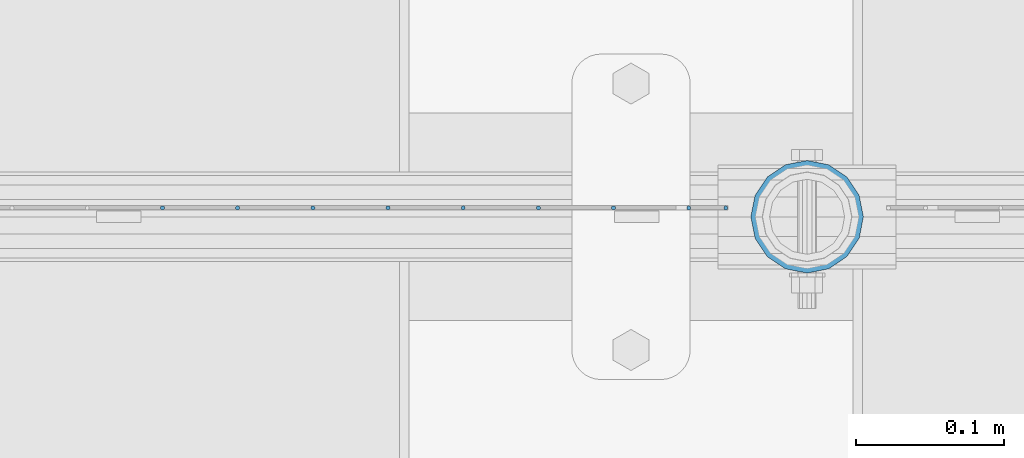
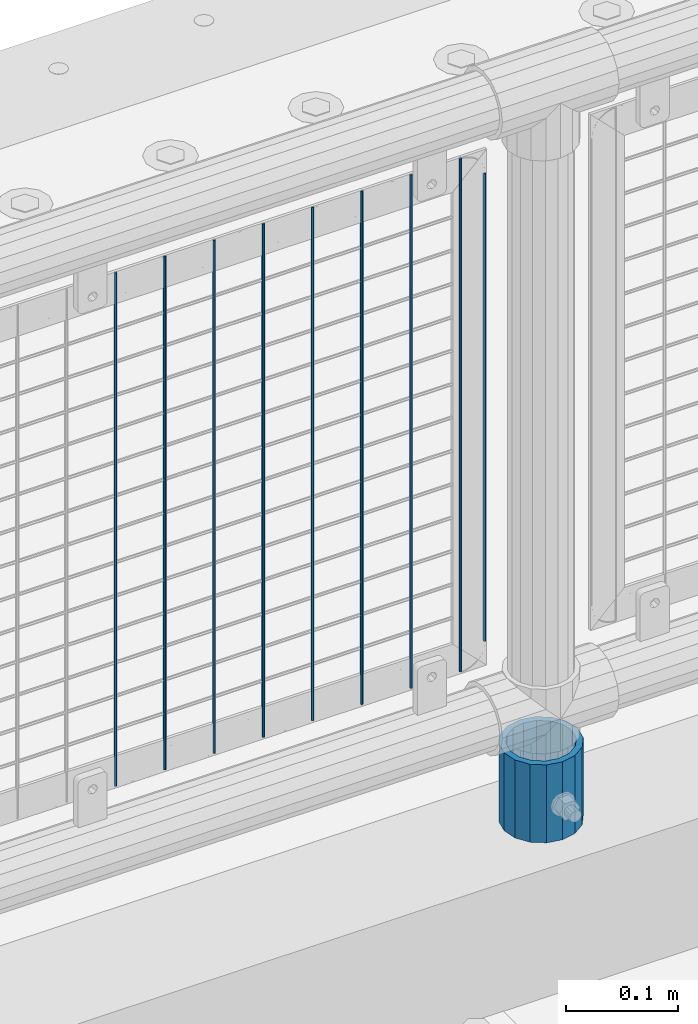
# One storey, part 85 of 242: 10 columns.
"""IFC2X3 building model written with IfcOpenShell, lengths in millimetres."""

from ifc_helpers import new_model, si_unit, frame, origin_with_axes, place, context, subcontext, project, spatial, faceted_brep, material, type_object, element, save


model = new_model("IFC2X3")

# Units and contexts
model_context = context("Model", 3, precision=1e-05, world=origin_with_axes())
body_context = subcontext(model_context, "Body", "Model", "MODEL_VIEW")
ifc_project = project(units=[si_unit("LENGTHUNIT", "METRE", prefix="MILLI"), si_unit("AREAUNIT", "SQUARE_METRE"), si_unit("VOLUMEUNIT", "CUBIC_METRE"), si_unit("MASSUNIT", "GRAM", prefix="KILO"), si_unit("TIMEUNIT", "SECOND"), si_unit("PLANEANGLEUNIT", "RADIAN"), si_unit("SOLIDANGLEUNIT", "STERADIAN"), si_unit("THERMODYNAMICTEMPERATUREUNIT", "DEGREE_CELSIUS"), si_unit("LUMINOUSINTENSITYUNIT", "LUMEN")], contexts=[model_context])

# Site, building, storey
site_placement = place(None, origin_with_axes())
site = spatial("IfcSite", under=ifc_project, at=site_placement, CompositionType="ELEMENT")
building_placement = place(site_placement, origin_with_axes())
building = spatial("IfcBuilding", under=site, at=building_placement, Name="Standard", CompositionType="ELEMENT")
storey_placement = place(building_placement, origin_with_axes())
storey = spatial("IfcBuildingStorey", under=building, at=storey_placement, Name="Undefined", CompositionType="ELEMENT", Elevation=0.0)

# Columns
ifc_material_1 = material(Name="Misc_Undefined")
column_type_1 = type_object("IfcColumnType", Name="D3", PredefinedType="NOTDEFINED")
for number, where, z_axis, x_axis in (
    (1, (-32161.796, -19329.5, 353.02), (-1.0, 0.0, 0.0), (0.0, 0.0, 1.0)),
    (2, (-32212.589, -19329.5, 353.02), (-1.0, 0.0, 0.0), (0.0, 0.0, 1.0)),
    (3, (-32263.382, -19329.5, 353.02), (-1.0, 0.0, 0.0), (0.0, 0.0, 1.0)),
    (4, (-32314.175, -19329.5, 353.02), (-1.0, 0.0, 0.0), (0.0, 0.0, 1.0)),
    (5, (-32364.968, -19329.5, 353.02), (-1.0, 0.0, 0.0), (0.0, 0.0, 1.0)),
    (6, (-32415.761, -19329.5, 353.02), (-1.0, 0.0, 0.0), (0.0, 0.0, 1.0)),
    (7, (-32466.554, -19329.5, 353.02), (-1.0, 0.0, 0.0), (0.0, 0.0, 1.0)),
    (8, (-32111.003, -19329.5, 353.02), (-1.0, 0.0, 0.0), (0.0, 0.0, 1.0)),
):
    element("IfcColumn", number, at=place(storey_placement, frame(where, z_axis=z_axis, x_axis=x_axis)), inside=storey, type_object=column_type_1, material=ifc_material_1, ObjectType="D3", context=body_context, shape_type="Brep", body=[
        faceted_brep([(0.0, -1.50000000000364, 0.0), (-3.63797880709171e-12, -0.750000000003638, -1.29903810567669), (560.0, -0.75, -1.29903810567703), (560.0, -1.5, 0.0), (0.0, 0.749999999996362, -1.29903810567669), (560.0, 0.75, -1.29903810567703), (-3.63797880709171e-12, 1.49999999999636, 0.0), (560.0, 1.5, 0.0), (0.0, 0.749999999996362, 1.29903810567669), (560.0, 0.75, 1.29903810567703), (-3.63797880709171e-12, -0.750000000003638, 1.29903810567669), (560.0, -0.75, 1.29903810567703)], [[[0, 1, 2, 3]], [[1, 4, 5, 2]], [[4, 6, 7, 5]], [[6, 8, 9, 7]], [[8, 10, 11, 9]], [[10, 0, 3, 11]], [[5, 7, 9, 11, 3, 2]], [[10, 8, 6, 4, 1, 0]]]),
    ])
column_1_placement = place(storey_placement, frame((-32086.0, -19329.5, 378.02), z_axis=(-1.0, 0.0, 0.0), x_axis=(0.0, 0.0, 1.0)))
element("IfcColumn", 9, at=column_1_placement, inside=storey, type_object=column_type_1, material=ifc_material_1, ObjectType="D3", context=body_context, shape_type="Brep", body=[
    faceted_brep([(0.0, -1.50000000000364, 0.0), (-3.63797880709171e-12, -0.750000000003638, -1.29903810567669), (510.0, -0.75, -1.29903810567703), (510.0, -1.5, 0.0), (0.0, 0.749999999996362, -1.29903810567669), (510.0, 0.75, -1.29903810567703), (-3.63797880709171e-12, 1.49999999999636, 0.0), (510.0, 1.5, 0.0), (0.0, 0.749999999996362, 1.29903810567669), (510.0, 0.75, 1.29903810567703), (-3.63797880709171e-12, -0.750000000003638, 1.29903810567669), (510.0, -0.75, 1.29903810567703)], [[[0, 1, 2, 3]], [[1, 4, 5, 2]], [[4, 6, 7, 5]], [[6, 8, 9, 7]], [[8, 10, 11, 9]], [[10, 0, 3, 11]], [[5, 7, 9, 11, 3, 2]], [[10, 8, 6, 4, 1, 0]]]),
])
ifc_material_2 = material()
column_type_2 = type_object("IfcColumnType", PredefinedType="NOTDEFINED")
column_2_placement = place(storey_placement, frame((-32031.0, -19335.5, 168.02), z_axis=(0.0, 1.0, 0.0), x_axis=(0.0, 0.0, 1.0)))
element("IfcColumn", 10, at=column_2_placement, inside=storey, type_object=column_type_2, material=ifc_material_2, context=body_context, shape_type="Brep", body=[
    faceted_brep([(0.0, -31.75, 0.0), (0.0, -29.3331751572332, 12.1501989775934), (85.0, -29.3331751572332, 12.1501989775934), (85.0, -31.75, 0.0), (0.0, -22.4506403026717, 22.4506403026717), (85.0, -22.4506403026717, 22.4506403026717), (0.0, -12.1501989775934, 29.3331751572332), (85.0, -12.1501989775934, 29.3331751572332), (0.0, 0.0, 31.75), (85.0, 0.0, 31.75), (0.0, 12.1501989775934, 29.3331751572332), (85.0, 12.1501989775934, 29.3331751572332), (0.0, 22.4506403026717, 22.4506403026717), (85.0, 22.4506403026717, 22.4506403026717), (0.0, 29.3331751572332, 12.1501989775934), (85.0, 29.3331751572332, 12.1501989775934), (0.0, 31.75, 0.0), (85.0, 31.75, 0.0), (0.0, 29.3331751572332, -12.1501989775934), (85.0, 29.3331751572332, -12.1501989775934), (0.0, 22.4506403026717, -22.4506403026717), (85.0, 22.4506403026717, -22.4506403026717), (0.0, 12.1501989775934, -29.3331751572332), (85.0, 12.1501989775934, -29.3331751572332), (0.0, 0.0, -31.75), (85.0, 0.0, -31.75), (0.0, -12.1501989775934, -29.3331751572332), (85.0, -12.1501989775934, -29.3331751572332), (0.0, -22.4506403026717, -22.4506403026717), (85.0, -22.4506403026717, -22.4506403026717), (0.0, -29.3331751572332, -12.1501989775934), (85.0, -29.3331751572332, -12.1501989775934), (0.0, -38.0499999999993, 0.0), (0.0, -35.1536162120537, -14.5611046014928), (85.0, -35.1536162120537, -14.5611046014928), (85.0, -38.0499999999993, 0.0), (0.0, -26.9054130241493, -26.9054130241493), (85.0, -26.9054130241493, -26.9054130241493), (0.0, -14.5611046014928, -35.1536162120537), (85.0, -14.5611046014928, -35.1536162120537), (0.0, 0.0, -38.0499999999993), (85.0, 0.0, -38.0499999999993), (0.0, 14.5611046014928, -35.1536162120537), (85.0, 14.5611046014928, -35.1536162120537), (0.0, 26.9054130241493, -26.9054130241493), (85.0, 26.9054130241493, -26.9054130241493), (0.0, 35.1536162120537, -14.5611046014928), (85.0, 35.1536162120537, -14.5611046014928), (0.0, 38.0499999999993, 0.0), (85.0, 38.0499999999993, 0.0), (0.0, 35.1536162120537, 14.5611046014928), (85.0, 35.1536162120537, 14.5611046014928), (0.0, 26.9054130241493, 26.9054130241493), (85.0, 26.9054130241493, 26.9054130241493), (0.0, 14.5611046014928, 35.1536162120537), (85.0, 14.5611046014928, 35.1536162120537), (0.0, 0.0, 38.0499999999993), (85.0, 0.0, 38.0499999999993), (0.0, -14.5611046014928, 35.1536162120537), (85.0, -14.5611046014928, 35.1536162120537), (0.0, -26.9054130241493, 26.9054130241493), (85.0, -26.9054130241493, 26.9054130241493), (0.0, -35.1536162120537, 14.5611046014928), (85.0, -35.1536162120537, 14.5611046014928)], [[[0, 1, 2, 3]], [[1, 4, 5, 2]], [[4, 6, 7, 5]], [[6, 8, 9, 7]], [[8, 10, 11, 9]], [[10, 12, 13, 11]], [[12, 14, 15, 13]], [[14, 16, 17, 15]], [[16, 18, 19, 17]], [[18, 20, 21, 19]], [[20, 22, 23, 21]], [[22, 24, 25, 23]], [[24, 26, 27, 25]], [[26, 28, 29, 27]], [[28, 30, 31, 29]], [[30, 0, 3, 31]], [[32, 33, 34, 35]], [[33, 36, 37, 34]], [[36, 38, 39, 37]], [[38, 40, 41, 39]], [[40, 42, 43, 41]], [[42, 44, 45, 43]], [[44, 46, 47, 45]], [[46, 48, 49, 47]], [[48, 50, 51, 49]], [[50, 52, 53, 51]], [[52, 54, 55, 53]], [[54, 56, 57, 55]], [[56, 58, 59, 57]], [[58, 60, 61, 59]], [[60, 62, 63, 61]], [[62, 32, 35, 63]], [[37, 39, 41, 43, 45, 47, 49, 51, 53, 55, 57, 59, 61, 63, 35, 34], [5, 7, 9, 11, 13, 15, 17, 19, 21, 23, 25, 27, 29, 31, 3, 2]], [[62, 60, 58, 56, 54, 52, 50, 48, 46, 44, 42, 40, 38, 36, 33, 32], [30, 28, 26, 24, 22, 20, 18, 16, 14, 12, 10, 8, 6, 4, 1, 0]]]),
])

save(model, "model.ifc")
